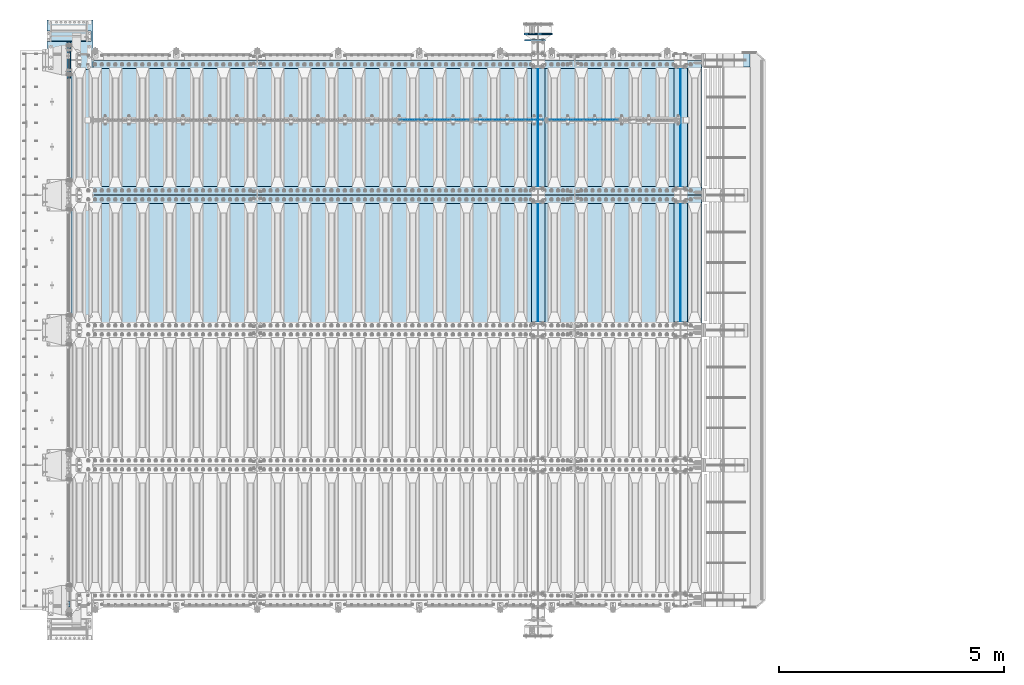
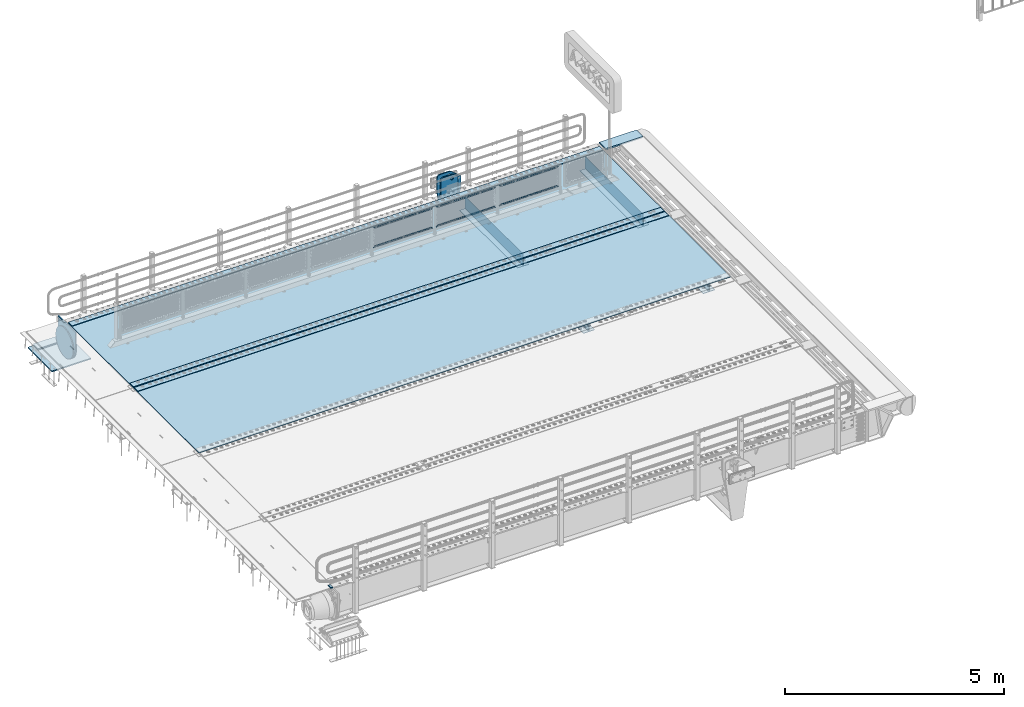
# One storey, part 189 of 240: 27 plates.
"""IFC2X3 building model written with IfcOpenShell, lengths in millimetres."""

from ifc_helpers import new_model, si_unit, frame, origin_with_axes, place, context, subcontext, project, spatial, faceted_brep, material, type_object, element, save


model = new_model("IFC2X3")

# Units and contexts
model_context = context("Model", 3, precision=1e-05, world=origin_with_axes())
body_context = subcontext(model_context, "Body", "Model", "MODEL_VIEW")
ifc_project = project(units=[si_unit("LENGTHUNIT", "METRE", prefix="MILLI"), si_unit("AREAUNIT", "SQUARE_METRE"), si_unit("VOLUMEUNIT", "CUBIC_METRE"), si_unit("MASSUNIT", "GRAM", prefix="KILO"), si_unit("TIMEUNIT", "SECOND"), si_unit("PLANEANGLEUNIT", "RADIAN"), si_unit("SOLIDANGLEUNIT", "STERADIAN"), si_unit("THERMODYNAMICTEMPERATUREUNIT", "DEGREE_CELSIUS"), si_unit("LUMINOUSINTENSITYUNIT", "LUMEN")], contexts=[model_context])

# Site, building, storey
site_placement = place(None, origin_with_axes())
site = spatial("IfcSite", under=ifc_project, at=site_placement, CompositionType="ELEMENT")
building_placement = place(site_placement, origin_with_axes())
building = spatial("IfcBuilding", under=site, at=building_placement, Name="Standard", CompositionType="ELEMENT")
storey_placement = place(building_placement, origin_with_axes())
storey = spatial("IfcBuildingStorey", under=building, at=storey_placement, Name="Undefined", CompositionType="ELEMENT", Elevation=0.0)

# Plates
ifc_material_1 = material()
plate_type_1 = type_object("IfcPlateType", PredefinedType="NOTDEFINED")
plate_1_placement = place(storey_placement, frame((42439.9999999402, 23910.0000004321, -15.9997988354379), z_axis=(-1.0, 0.0, 0.0), x_axis=(0.0, -4.95099997756316e-06, 0.999999999987744)))
element("IfcPlate", 1, at=plate_1_placement, inside=storey, type_object=plate_type_1, material=ifc_material_1, context=body_context, shape_type="Brep", body=[
    faceted_brep([(3.5527136788005e-15, -60.0, 0.0), (-0.000933120085687023, -60.0000000000036, 60.0), (-0.000933120085687023, 60.0, 59.9999999999927), (0.0, 60.0000000000036, -7.27595761418343e-12), (24.9991450303709, -60.0, 60.0), (24.9991450303709, 59.9999999999964, 59.9999999999927), (26.544215218168, -60.0000000000036, 59.7552873850873), (26.544215218168, 60.0, 59.75528738508), (27.9380461396139, -60.0, 59.0451032459096), (27.9380461396139, 60.0, 59.0451032459096), (29.0442025908961, -60.0, 57.9389639895744), (29.0442025908961, 60.0, 57.9389639895744), (29.7544083969366, -60.0, 56.5451441080368), (29.7544083969366, 60.0000000000036, 56.5451441080295), (29.9991450297669, -60.0000000000036, 55.0000777244568), (29.9991450297669, 60.0, 55.0000777244495), (29.999922274335, -60.0, 5.00007772445679), (29.999922274335, 60.0, 5.00007772444951), (29.7552240705896, -60.0000000000036, 3.45497416452417), (29.7552240705896, 60.0, 3.45497416452417), (29.0450346578116, -60.0, 2.06111146690819), (29.0450346578116, 60.0, 2.06111146690819), (27.9388736885073, -60.0, 0.954933302316931), (27.9388736885072, 59.9999999999964, 0.954933302316931), (26.5450220308766, -60.0000000000036, 0.244722222181736), (26.5450220308766, 60.0, 0.244722222181736), (24.9999222749392, -59.9999999999964, 0.0), (24.9999222749392, 60.0, -7.27595761418343e-12)], [[[0, 1, 2, 3]], [[1, 4, 5, 2]], [[4, 6, 7, 5]], [[6, 8, 9, 7]], [[8, 10, 11, 9]], [[10, 12, 13, 11]], [[12, 14, 15, 13]], [[14, 16, 17, 15]], [[16, 18, 19, 17]], [[18, 20, 21, 19]], [[20, 22, 23, 21]], [[22, 24, 25, 23]], [[24, 26, 27, 25]], [[26, 0, 3, 27]], [[5, 7, 9, 11, 13, 15, 17, 19, 21, 23, 25, 27, 3, 2]], [[26, 24, 22, 20, 18, 16, 14, 12, 10, 8, 6, 4, 1, 0]]]),
])
ifc_material_2 = material(Name="STEEL/S355N")
plate_type_2 = type_object("IfcPlateType", PredefinedType="NOTDEFINED")
for number, where, z_axis, x_axis in (
    (2, (56005.0, 32825.0, 0.0), (0.0, 0.0, -1.0), (0.0, -1.0, 0.0)),
    (3, (56005.0, 35825.0, 0.0), (0.0, 0.0, -1.0), (0.0, -1.0, 0.0)),
    (4, (52840.0, 32825.0, 0.0), (0.0, 0.0, -1.0), (0.0, -1.0, 0.0)),
    (5, (52840.0, 35825.0, 0.0), (0.0, 0.0, -1.0), (0.0, -1.0, 0.0)),
):
    element("IfcPlate", number, at=place(storey_placement, frame(where, z_axis=z_axis, x_axis=x_axis)), inside=storey, type_object=plate_type_2, material=ifc_material_2, context=body_context, shape_type="Brep", body=[
        faceted_brep([(0.0, -5.0, 0.0), (0.0, -5.0, 336.0), (0.0, 5.0, 336.0), (0.0, 5.0, 0.0), (2650.0, -5.0, 336.0), (2650.0, 5.0, 336.0), (2650.0, -5.0, 0.0), (2650.0, 5.0, 0.0)], [[[0, 1, 2, 3]], [[1, 4, 5, 2]], [[4, 6, 7, 5]], [[6, 0, 3, 7]], [[5, 7, 3, 2]], [[6, 4, 1, 0]]]),
    ])
plate_type_3 = type_object("IfcPlateType", PredefinedType="NOTDEFINED")
for number, where, z_axis, x_axis in (
    (6, (55855.0, 30175.0, -343.0), (0.0, 1.0, 0.0), (1.0, 0.0, 0.0)),
    (7, (55855.0, 33175.0, -343.0), (0.0, 1.0, 0.0), (1.0, 0.0, 0.0)),
    (8, (52690.0, 30175.0, -343.0), (0.0, 1.0, 0.0), (1.0, 0.0, 0.0)),
    (9, (52690.0, 33175.0, -343.0), (0.0, 1.0, 0.0), (1.0, 0.0, 0.0)),
):
    element("IfcPlate", number, at=place(storey_placement, frame(where, z_axis=z_axis, x_axis=x_axis)), inside=storey, type_object=plate_type_3, material=ifc_material_2, context=body_context, shape_type="Brep", body=[
        faceted_brep([(0.0, -7.0, 0.0), (0.0, -7.0, 2650.0), (0.0, 7.0, 2650.0), (0.0, 7.0, 0.0), (300.0, -7.0, 2650.0), (300.0, 7.0, 2650.0), (300.0, -7.0, 0.0), (300.0, 7.0, 0.0)], [[[0, 1, 2, 3]], [[1, 4, 5, 2]], [[4, 6, 7, 5]], [[6, 0, 3, 7]], [[5, 7, 3, 2]], [[6, 4, 1, 0]]]),
    ])
ifc_material_3 = material(Name="Misc_Undefined")
plate_type_4 = type_object("IfcPlateType", PredefinedType="NOTDEFINED")
plate_2_placement = place(storey_placement, frame((53072.5050117304, 34670.5, 351.520303374641), z_axis=(0.0, 0.0, 1.0), x_axis=(1.0, 0.0, 0.0)))
element("IfcPlate", 10, at=plate_2_placement, inside=storey, type_object=plate_type_4, material=ifc_material_3, context=body_context, shape_type="Brep", body=[
    faceted_brep([(-7.27595761418343e-12, -1.49999999999272, 0.0), (35.000297546394, -1.5, 34.9996948242186), (35.000297546394, 1.5, 34.9996948242186), (0.0, 1.50000000000728, 0.0), (1515.99035644533, -1.5, 34.9999923706054), (1515.99035644533, 1.5, 34.9999923706054), (1550.98999023439, -1.5, 4.43031922259252e-09), (1550.98999023439, 1.5, 4.43031922259252e-09)], [[[0, 1, 2, 3]], [[1, 4, 5, 2]], [[4, 6, 7, 5]], [[6, 0, 3, 7]], [[5, 7, 3, 2]], [[6, 4, 1, 0]]]),
])
plate_3_placement = place(storey_placement, frame((54623.5000001876, 34670.5, 914.520000175701), z_axis=(-0.707103624179501, 0.0, 0.707109938179499), x_axis=(-0.707109938179504, 0.0, -0.707103624179496)))
element("IfcPlate", 11, at=plate_3_placement, inside=storey, type_object=plate_type_4, material=ifc_material_3, context=body_context, shape_type="Brep", body=[
    faceted_brep([(-7.27595761418343e-12, -1.49999999999272, 0.0), (1096.72753906249, -1.5, 1096.7177734375), (1096.72753906249, 1.5, 1096.7177734375), (0.0, 1.50000000000728, 0.0), (1096.72045898437, -1.5, 1047.21337890625), (1096.72045898437, 1.5, 1047.21337890625), (49.4976959228443, -1.5, -1.09139364212751e-10), (49.4976959228443, 1.5, -1.09139364212751e-10)], [[[0, 1, 2, 3]], [[1, 4, 5, 2]], [[4, 6, 7, 5]], [[6, 0, 3, 7]], [[5, 7, 3, 2]], [[6, 4, 1, 0]]]),
])
plate_4_placement = place(storey_placement, frame((51414.5050117304, 34670.5, 351.520303374641), z_axis=(0.0, 0.0, 1.0), x_axis=(1.0, 0.0, 0.0)))
element("IfcPlate", 12, at=plate_4_placement, inside=storey, type_object=plate_type_4, material=ifc_material_3, context=body_context, shape_type="Brep", body=[
    faceted_brep([(-7.27595761418343e-12, -1.49999999999272, 0.0), (35.000297546394, -1.5, 34.9996948242186), (35.000297546394, 1.5, 34.9996948242186), (0.0, 1.50000000000728, 0.0), (1515.99035644533, -1.5, 34.9999923706054), (1515.99035644533, 1.5, 34.9999923706054), (1550.98999023439, -1.5, 4.43031922259252e-09), (1550.98999023439, 1.5, 4.43031922259252e-09)], [[[0, 1, 2, 3]], [[1, 4, 5, 2]], [[4, 6, 7, 5]], [[6, 0, 3, 7]], [[5, 7, 3, 2]], [[6, 4, 1, 0]]]),
])
plate_5_placement = place(storey_placement, frame((52965.5000001876, 34670.5, 914.520000175701), z_axis=(-0.707103624179501, 0.0, 0.707109938179499), x_axis=(-0.707109938179504, 0.0, -0.707103624179496)))
element("IfcPlate", 13, at=plate_5_placement, inside=storey, type_object=plate_type_4, material=ifc_material_3, context=body_context, shape_type="Brep", body=[
    faceted_brep([(-7.27595761418343e-12, -1.49999999999272, 0.0), (1096.72753906249, -1.5, 1096.7177734375), (1096.72753906249, 1.5, 1096.7177734375), (0.0, 1.50000000000728, 0.0), (1096.72045898437, -1.5, 1047.21337890625), (1096.72045898437, 1.5, 1047.21337890625), (49.4976959228443, -1.5, -1.09139364212751e-10), (49.4976959228443, 1.5, -1.09139364212751e-10)], [[[0, 1, 2, 3]], [[1, 4, 5, 2]], [[4, 6, 7, 5]], [[6, 0, 3, 7]], [[5, 7, 3, 2]], [[6, 4, 1, 0]]]),
])
plate_6_placement = place(storey_placement, frame((49756.5050117304, 34670.5, 351.520303374641), z_axis=(0.0, 0.0, 1.0), x_axis=(1.0, 0.0, 0.0)))
element("IfcPlate", 14, at=plate_6_placement, inside=storey, type_object=plate_type_4, material=ifc_material_3, context=body_context, shape_type="Brep", body=[
    faceted_brep([(-7.27595761418343e-12, -1.49999999999272, 0.0), (35.000297546394, -1.5, 34.9996948242186), (35.000297546394, 1.5, 34.9996948242186), (0.0, 1.50000000000728, 0.0), (1515.99035644533, -1.5, 34.9999923706054), (1515.99035644533, 1.5, 34.9999923706054), (1550.98999023439, -1.5, 4.43031922259252e-09), (1550.98999023439, 1.5, 4.43031922259252e-09)], [[[0, 1, 2, 3]], [[1, 4, 5, 2]], [[4, 6, 7, 5]], [[6, 0, 3, 7]], [[5, 7, 3, 2]], [[6, 4, 1, 0]]]),
])
plate_7_placement = place(storey_placement, frame((51307.5000001876, 34670.5, 914.520000175701), z_axis=(-0.707103624179501, 0.0, 0.707109938179499), x_axis=(-0.707109938179504, 0.0, -0.707103624179496)))
element("IfcPlate", 15, at=plate_7_placement, inside=storey, type_object=plate_type_4, material=ifc_material_3, context=body_context, shape_type="Brep", body=[
    faceted_brep([(-7.27595761418343e-12, -1.49999999999272, 0.0), (1096.72753906249, -1.5, 1096.7177734375), (1096.72753906249, 1.5, 1096.7177734375), (0.0, 1.50000000000728, 0.0), (1096.72045898437, -1.5, 1047.21337890625), (1096.72045898437, 1.5, 1047.21337890625), (49.4976959228443, -1.5, -1.09139364212751e-10), (49.4976959228443, 1.5, -1.09139364212751e-10)], [[[0, 1, 2, 3]], [[1, 4, 5, 2]], [[4, 6, 7, 5]], [[6, 0, 3, 7]], [[5, 7, 3, 2]], [[6, 4, 1, 0]]]),
])
plate_type_5 = type_object("IfcPlateType", PredefinedType="NOTDEFINED")
plate_8_placement = place(storey_placement, frame((56556.9988298905, 36150.0, -10.0000000004865), z_axis=(1.0, 0.0, 0.0), x_axis=(0.0, -1.0, 0.0)))
element("IfcPlate", 16, at=plate_8_placement, inside=storey, type_object=plate_type_5, material=ifc_material_2, context=body_context, shape_type="Brep", body=[
    faceted_brep([(300.0, 7.0, 986.0), (300.0, 20.0, 956.0), (-3.63797880709171e-11, 20.0, 956.0), (-3.63797880709171e-11, 7.0, 986.0), (0.0, 20.0, 0.0), (0.0, -20.0, 0.0), (-3.63797880709171e-11, -20.0, 986.0), (300.0, -20.0, 986.0), (300.0, -20.0, -1.81898940354586e-12), (300.0, 20.0, -1.81898940354586e-12)], [[[0, 1, 2, 3]], [[4, 5, 6, 3, 2]], [[6, 7, 0, 3]], [[7, 8, 9, 1, 0]], [[8, 5, 4, 9]], [[9, 4, 2, 1]], [[8, 7, 6, 5]]]),
])
plate_type_6 = type_object("IfcPlateType", PredefinedType="NOTDEFINED")
plate_9_placement = place(storey_placement, frame((42905.0, 36645.0, -803.000000000004), z_axis=(0.0, -1.0, 0.0), x_axis=(-1.0, 0.0, 0.0)))
element("IfcPlate", 17, at=plate_9_placement, inside=storey, type_object=plate_type_6, material=ifc_material_1, context=body_context, shape_type="Brep", body=[
    faceted_brep([(0.0, 0.0, 235.0), (0.0, -15.0, 220.0), (979.0, -15.0, 220.0), (979.0, 0.0, 235.0), (0.0, 15.0, 235.0), (0.0, 15.0, 0.0), (0.0, -15.0, 0.0), (979.0, 15.0, 235.0), (979.0, -15.0, 0.0), (979.0, 15.0, 0.0)], [[[0, 1, 2, 3]], [[4, 5, 6, 1, 0]], [[7, 4, 0, 3]], [[8, 9, 7, 3, 2]], [[8, 6, 5, 9]], [[7, 9, 5, 4]], [[6, 8, 2, 1]]]),
])
plate_type_7 = type_object("IfcPlateType", PredefinedType="NOTDEFINED")
plate_10_placement = place(storey_placement, frame((41926.0, 36890.0, -1043.0), z_axis=(1.0, 0.0, 0.0), x_axis=(0.0, -1.0, 0.0)))
element("IfcPlate", 18, at=plate_10_placement, inside=storey, type_object=plate_type_7, material=ifc_material_1, context=body_context, shape_type="Brep", body=[
    faceted_brep([(0.0, -15.0, 0.0), (3.03448323393241e-05, -15.0, 1025.0), (3.03448323393241e-05, 15.0, 1025.0), (0.0, 15.0, 0.0), (1100.0, -15.0, 1025.0), (1100.0, 15.0, 1025.0), (1100.0, -15.0, -2.18278728425503e-11), (1100.0, 15.0, -2.18278728425503e-11)], [[[0, 1, 2, 3]], [[1, 4, 5, 2]], [[4, 6, 7, 5]], [[6, 0, 3, 7]], [[5, 7, 3, 2]], [[6, 4, 1, 0]]]),
])
plate_type_8 = type_object("IfcPlateType", PredefinedType="NOTDEFINED")
plate_11_placement = place(storey_placement, frame((42387.5, 36400.0, -114.999999999998), z_axis=(0.0, 0.0, -1.0), x_axis=(0.0, -1.0, 0.0)))
element("IfcPlate", 19, at=plate_11_placement, inside=storey, type_object=plate_type_8, material=ifc_material_2, context=body_context, shape_type="Brep", body=[
    faceted_brep([(0.0, -12.5, 400.0), (2.91645036072441, -12.5, 448.214672101647), (2.91645036072441, 12.5, 448.214672101647), (0.0, 12.5, 400.0), (11.6232730294796, -12.5, 495.726265714562), (11.6232730294796, 12.5, 495.726265714562), (25.9935029256958, -12.5, 541.841954816598), (25.9935029256958, 12.5, 541.841954816598), (45.8175897385445, -12.5, 585.889268817169), (45.8175897385445, 12.5, 585.889268817169), (70.8064536423408, -12.5, 627.22589869221), (70.8064536423408, 12.5, 627.22589869221), (100.595700731341, -12.5, 665.24906329616), (100.595700731341, 12.5, 665.24906329616), (134.750936703451, -12.5, 699.40429926839), (134.750936703451, 12.5, 699.40429926839), (172.774101307281, -12.5, 729.193546357525), (172.774101307281, 12.5, 729.193546357525), (214.11073118222, -12.5, 754.182410261448), (214.11073118222, 12.5, 754.182410261448), (258.158045182681, -12.5, 774.006497074428), (258.158045182681, 12.5, 774.006497074428), (304.273734284623, -12.5, 788.376726970779), (304.273734284623, 12.5, 788.376726970779), (351.785327897465, -12.5, 797.083549639658), (351.785327897465, 12.5, 797.083549639658), (400.0, -12.5, 800.0), (400.0, 12.5, 800.0), (448.21467210335, -12.5, 797.083549637646), (448.21467210335, 12.5, 797.083549637646), (495.726265715995, -12.5, 788.37672696916), (495.726265715995, 12.5, 788.37672696916), (541.841954817748, -12.5, 774.006497073235), (541.841954817748, 12.5, 774.006497073235), (585.889268818006, -12.5, 754.182410260695), (585.889268818006, 12.5, 754.182410260695), (627.225898692734, -12.5, 729.193546357212), (627.225898692734, 12.5, 729.193546357212), (665.24906329636, -12.5, 699.404299268539), (665.24906329636, 12.5, 699.404299268539), (699.404299268259, -12.5, 665.24906329676), (699.404299268259, 12.5, 665.24906329676), (729.193546357063, -12.5, 627.22589869325), (729.193546357063, 12.5, 627.22589869325), (754.18241026067, -12.5, 585.889268818639), (754.18241026067, 12.5, 585.889268818639), (774.006497073351, -12.5, 541.841954818479), (774.006497073351, 12.5, 541.841954818479), (788.376726969393, -12.5, 495.726265716821), (788.376726969393, 12.5, 495.726265716821), (797.083549638002, -12.5, 448.214672104252), (797.083549638002, 12.5, 448.214672104252), (800.0, -12.5, 400.0), (800.0, 12.5, 400.0), (797.083549639283, -12.5, 351.785327898364), (797.083549639283, 12.5, 351.785327898364), (788.376726970528, -12.5, 304.273734285453), (788.376726970528, 12.5, 304.273734285453), (774.006497074311, -12.5, 258.158045183416), (774.006497074311, 12.5, 258.158045183416), (754.182410261463, -12.5, 214.110731182853), (754.182410261463, 12.5, 214.110731182853), (729.193546357659, -12.5, 172.774101307812), (729.193546357659, 12.5, 172.774101307812), (699.404299268659, -12.5, 134.750936703855), (699.404299268659, 12.5, 134.750936703855), (665.249063296564, -12.5, 100.595700731628), (665.249063296564, 12.5, 100.595700731628), (627.225898692719, -12.5, 70.8064536425045), (627.225898692719, 12.5, 70.8064536425045), (585.889268817788, -12.5, 45.8175897385809), (585.889268817788, 12.5, 45.8175897385809), (541.841954817326, -12.5, 25.9935029256012), (541.841954817326, 12.5, 25.9935029256012), (495.726265715377, -12.5, 11.6232730292504), (495.726265715377, 12.5, 11.6232730292504), (448.214672102542, -12.5, 2.91645036037517), (448.214672102542, 12.5, 2.91645036037517), (400.0, -12.5, -5.6843418860808e-14), (400.0, 12.5, -5.6843418860808e-14), (351.785327896665, -12.5, 2.91645036236514), (351.785327896665, 12.5, 2.91645036236514), (304.273734284012, -12.5, 11.6232730308511), (304.273734284012, 12.5, 11.6232730308511), (258.158045182267, -12.5, 25.9935029267763), (258.158045182267, 12.5, 25.9935029267763), (214.110731182009, -12.5, 45.8175897393157), (214.110731182009, 12.5, 45.8175897393157), (172.774101307281, -12.5, 70.8064536427992), (172.774101307281, 12.5, 70.8064536427992), (134.750936703655, -12.5, 100.595700731472), (134.750936703655, 12.5, 100.595700731472), (100.595700731748, -12.5, 134.750936703247), (100.595700731748, 12.5, 134.750936703247), (70.8064536429447, -12.5, 172.774101306761), (70.8064536429447, 12.5, 172.774101306761), (45.8175897393376, -12.5, 214.110731181379), (45.8175897393376, 12.5, 214.110731181379), (25.9935029266635, -12.5, 258.158045181532), (25.9935029266635, 12.5, 258.158045181532), (11.6232730306074, -12.5, 304.273734283186), (11.6232730306074, 12.5, 304.273734283186), (2.9164503619977, -12.5, 351.785327895759), (2.9164503619977, 12.5, 351.785327895759)], [[[0, 1, 2, 3]], [[1, 4, 5, 2]], [[4, 6, 7, 5]], [[6, 8, 9, 7]], [[8, 10, 11, 9]], [[10, 12, 13, 11]], [[12, 14, 15, 13]], [[14, 16, 17, 15]], [[16, 18, 19, 17]], [[18, 20, 21, 19]], [[20, 22, 23, 21]], [[22, 24, 25, 23]], [[24, 26, 27, 25]], [[26, 28, 29, 27]], [[28, 30, 31, 29]], [[30, 32, 33, 31]], [[32, 34, 35, 33]], [[34, 36, 37, 35]], [[36, 38, 39, 37]], [[38, 40, 41, 39]], [[40, 42, 43, 41]], [[42, 44, 45, 43]], [[44, 46, 47, 45]], [[46, 48, 49, 47]], [[48, 50, 51, 49]], [[50, 52, 53, 51]], [[52, 54, 55, 53]], [[54, 56, 57, 55]], [[56, 58, 59, 57]], [[58, 60, 61, 59]], [[60, 62, 63, 61]], [[62, 64, 65, 63]], [[64, 66, 67, 65]], [[66, 68, 69, 67]], [[68, 70, 71, 69]], [[70, 72, 73, 71]], [[72, 74, 75, 73]], [[74, 76, 77, 75]], [[76, 78, 79, 77]], [[78, 80, 81, 79]], [[80, 82, 83, 81]], [[82, 84, 85, 83]], [[84, 86, 87, 85]], [[86, 88, 89, 87]], [[88, 90, 91, 89]], [[90, 92, 93, 91]], [[92, 94, 95, 93]], [[94, 96, 97, 95]], [[96, 98, 99, 97]], [[98, 100, 101, 99]], [[100, 102, 103, 101]], [[102, 0, 3, 103]], [[5, 7, 9, 11, 13, 15, 17, 19, 21, 23, 25, 27, 29, 31, 33, 35, 37, 39, 41, 43, 45, 47, 49, 51, 53, 55, 57, 59, 61, 63, 65, 67, 69, 71, 73, 75, 77, 79, 81, 83, 85, 87, 89, 91, 93, 95, 97, 99, 101, 103, 3, 2]], [[102, 100, 98, 96, 94, 92, 90, 88, 86, 84, 82, 80, 78, 76, 74, 72, 70, 68, 66, 64, 62, 60, 58, 56, 54, 52, 50, 48, 46, 44, 42, 40, 38, 36, 34, 32, 30, 28, 26, 24, 22, 20, 18, 16, 14, 12, 10, 8, 6, 4, 1, 0]]]),
])
ifc_material_4 = material(Name="STEEL/S235JR")
plate_type_9 = type_object("IfcPlateType", PredefinedType="NOTDEFINED")
for number, where, z_axis, x_axis in (
    (20, (56467.0, 32815.0, 20.0), (-1.0, 0.0, 0.0), (0.0, 1.0, 0.0)),
    (21, (56467.0, 35815.0, 20.0), (-1.0, 0.0, 0.0), (0.0, 1.0, 0.0)),
    (22, (56467.0, 33015.0, 20.0), (-1.0, 0.0, 0.0), (0.0, 1.0, 0.0)),
):
    element("IfcPlate", number, at=place(storey_placement, frame(where, z_axis=z_axis, x_axis=x_axis)), inside=storey, type_object=plate_type_9, material=ifc_material_4, context=body_context, shape_type="Brep", body=[
        faceted_brep([(0.0, -6.0, 0.0), (0.0, -6.0, 13997.0), (0.0, 6.0, 13997.0), (0.0, 6.0, 0.0), (170.0, -6.0, 13997.0), (170.0, 6.0, 13997.0), (170.0, -6.0, 0.0), (170.0, 6.0, 0.0)], [[[0, 1, 2, 3]], [[1, 4, 5, 2]], [[4, 6, 7, 5]], [[6, 0, 3, 7]], [[5, 7, 3, 2]], [[6, 4, 1, 0]]]),
    ])
plate_type_10 = type_object("IfcPlateType", PredefinedType="NOTDEFINED")
for number, where, z_axis, x_axis in (
    (23, (42460.0, 32995.0, 7.0), (1.0, 0.0, 0.0), (0.0, -1.0, 0.0)),
    (24, (42460.0, 35995.0, 7.0), (1.0, 0.0, 0.0), (0.0, -1.0, 0.0)),
):
    element("IfcPlate", number, at=place(storey_placement, frame(where, z_axis=z_axis, x_axis=x_axis)), inside=storey, type_object=plate_type_10, material=ifc_material_2, context=body_context, shape_type="Brep", body=[
        faceted_brep([(0.0, -7.0, 0.0), (-2.96859070658684e-09, -7.0, 14017.0), (-2.96859070658684e-09, 7.0, 14017.0), (0.0, 7.0, 0.0), (2990.0, -7.0, 14017.0), (2990.0, 7.0, 14017.0), (2990.0, -7.0, 0.0), (2990.0, 7.0, 0.0)], [[[0, 1, 2, 3]], [[1, 4, 5, 2]], [[4, 6, 7, 5]], [[6, 0, 3, 7]], [[5, 7, 3, 2]], [[6, 4, 1, 0]]]),
    ])
plate_type_11 = type_object("IfcPlateType", PredefinedType="NOTDEFINED")
plate_12_placement = place(storey_placement, frame((42445.0, 35600.0, -20.0), z_axis=(0.0, 1.0, 0.0), x_axis=(0.0, 0.0, -1.0)))
element("IfcPlate", 25, at=plate_12_placement, inside=storey, type_object=plate_type_11, material=ifc_material_2, context=body_context, shape_type="Brep", body=[
    faceted_brep([(855.0, -15.0, 572.96311467154), (855.0, 15.0, 572.96311467154), (849.182410261294, 15.0, 585.889268817533), (849.182410261294, -15.0, 585.889268817533), (824.193546357474, 15.0, 627.225898692486), (824.193546357474, -15.0, 627.225898692486), (794.404299268454, 15.0, 665.249063296338), (794.404299268454, -15.0, 665.249063296338), (760.249063296334, 15.0, 699.404299268463), (760.249063296334, -15.0, 699.404299268463), (722.22589869248, 15.0, 729.193546357485), (722.22589869248, -15.0, 729.193546357485), (680.889268817528, 15.0, 754.18241026131), (680.889268817528, -15.0, 754.18241026131), (636.841954817037, 15.0, 774.006497074195), (636.841954817037, -15.0, 774.006497074195), (590.726265715048, 15.0, 788.376726970448), (590.726265715048, -15.0, 788.376726970448), (543.214672102156, 15.0, 797.083549639254), (543.214672102156, -15.0, 797.083549639254), (495.0, -15.0, 800.000000000029), (495.0, 15.0, 800.0), (494.999999999412, -15.0, 0.0), (494.999999999412, 15.0, 0.0), (543.214672102129, 15.0, 2.91645036080809), (543.214672102129, -15.0, 2.91645036080809), (590.726265715023, 15.0, 11.6232730296069), (590.726265715023, -15.0, 11.6232730296069), (636.841954817014, 15.0, 25.9935029258631), (636.841954817014, -15.0, 25.9935029258631), (680.889268817507, 15.0, 45.8175897387446), (680.889268817507, -15.0, 45.8175897387446), (722.225898692462, 15.0, 70.8064536425663), (722.225898692462, -15.0, 70.8064536425663), (760.249063296318, 15.0, 100.595700731588), (760.249063296318, -15.0, 100.595700731588), (794.404299268441, 15.0, 134.750936703713), (794.404299268441, -15.0, 134.750936703713), (824.193546357463, 15.0, 172.774101307565), (824.193546357463, -15.0, 172.774101307565), (849.182410261284, 15.0, 214.110731182518), (849.182410261284, -15.0, 214.110731182518), (855.0, -15.0, 227.036885328533), (855.0, 15.0, 227.036885328533), (0.0, -15.0, 0.0), (0.0, 15.0, 0.0), (0.0, 15.0, 800.0), (0.0, -15.0, 800.0)], [[[0, 1, 2, 3]], [[3, 2, 4, 5]], [[5, 4, 6, 7]], [[7, 6, 8, 9]], [[9, 8, 10, 11]], [[11, 10, 12, 13]], [[13, 12, 14, 15]], [[15, 14, 16, 17]], [[17, 16, 18, 19]], [[20, 19, 18, 21]], [[22, 23, 24, 25]], [[25, 24, 26, 27]], [[27, 26, 28, 29]], [[29, 28, 30, 31]], [[31, 30, 32, 33]], [[33, 32, 34, 35]], [[35, 34, 36, 37]], [[37, 36, 38, 39]], [[39, 38, 40, 41]], [[42, 41, 40, 43]], [[42, 43, 1, 0]], [[44, 45, 23, 22]], [[16, 14, 12, 10, 8, 6, 4, 2, 1, 43, 40, 38, 36, 34, 32, 30, 28, 26, 24, 23, 45, 46, 21, 18]], [[44, 47, 46, 45]], [[46, 47, 20, 21]], [[47, 44, 22, 25, 27, 29, 31, 33, 35, 37, 39, 41, 42, 0, 3, 5, 7, 9, 11, 13, 15, 17, 19, 20]]]),
])
plate_type_12 = type_object("IfcPlateType", PredefinedType="NOTDEFINED")
plate_13_placement = place(storey_placement, frame((52999.9999999964, 36440.0000000348, -945.000018222272), z_axis=(-0.901283188008789, 0.0, 0.433230441004224), x_axis=(-0.433230441004219, 0.0, -0.901283188008791)))
element("IfcPlate", 26, at=plate_13_placement, inside=storey, type_object=plate_type_12, material=ifc_material_2, context=body_context, shape_type="Brep", body=[
    faceted_brep([(-929.368911797577, -15.0000000000146, 583.252555032144), (-929.368911797577, 14.9999999999854, 583.252555032144), (-937.308302015026, 14.9999999999854, 596.689503306923), (-937.308302015026, -15.0000000000146, 596.689503306923), (-939.501244651245, 14.9999999999854, 612.141897896698), (-939.501244651245, -15.0000000000146, 612.141897896698), (-935.613884068938, 14.9999999999854, 627.257251801486), (-935.613884068938, -15.0000000000146, 627.257251801486), (-926.238035677761, 14.9999999999854, 639.734389410303), (-926.238035677761, -15.0000000000146, 639.734389410303), (-912.801087402986, 14.9999999999854, 647.673779627759), (-912.801087402986, -15.0000000000146, 647.673779627759), (-897.348692813208, 14.9999999999854, 649.866722263971), (-897.348692813208, -15.0000000000146, 649.866722263971), (-882.23333890842, 14.9999999999854, 645.979361681668), (-882.23333890842, -15.0000000000146, 645.979361681668), (-869.756201299595, 14.9999999999854, 636.603513290487), (-869.756201299595, -15.0000000000146, 636.603513290487), (-861.81681108215, 14.9999999999854, 623.166565015716), (-861.81681108215, -15.0000000000146, 623.166565015716), (-859.623868445931, 14.9999999999854, 607.714170425934), (-859.623868445931, -15.0000000000146, 607.714170425934), (-863.511229028238, 14.9999999999854, 592.598816521153), (-863.511229028238, -15.0000000000146, 592.598816521153), (-872.887077419415, 14.9999999999854, 580.121678912328), (-872.887077419415, -15.0000000000146, 580.121678912328), (-886.32402569419, 14.9999999999854, 572.182288694879), (-886.32402569419, -15.0000000000146, 572.182288694879), (-901.776420283964, 14.9999999999854, 569.989346058661), (-901.776420283964, -15.0000000000146, 569.989346058661), (-916.891774188756, 14.9999999999854, 573.876706640964), (-916.891774188756, -15.0000000000146, 573.876706640964), (264.34993529279, -15.0, 42.1349931512304), (264.34993529279, 15.0, 42.1349931512304), (15.5957837248316, 15.0, 161.706590867936), (15.5957837248316, -15.0000000000073, 161.706590867936), (244.096420288082, -15.0, 2.25554686039686e-10), (244.096420288082, 15.0, 2.25554686039686e-10), (0.0, -15.0, 0.0), (0.0, 15.0, 0.0), (-976.801696777344, -15.0, 469.530822753899), (-976.801696777344, 15.0, 469.530822753899), (-1005.61094458149, -15.0, 584.572384687111), (-1005.61094458149, 15.0, 584.572384687111), (-1008.62082262311, -15.0, 603.3791105032), (-1008.62082262311, 15.0, 603.3791105032), (-1008.34150017789, -15.0, 622.423119553736), (-1008.34150017789, 15.0, 622.423119553736), (-1004.7813512013, -15.0, 641.133481415818), (-1004.7813512013, 15.0, 641.133481415818), (-998.047107283008, -15.0, 658.949268252029), (-998.047107283008, 15.0, 658.949268252029), (-903.393044122804, -15.0, 855.865689234553), (-903.393044122804, 15.0, 855.865689234553), (-891.965944990749, -15.0, 873.346279725993), (-891.965944990749, 15.0, 873.346279725993), (-876.403904176859, -15.0, 887.273681644823), (-876.403904176859, 15.0, 887.273681644823), (-857.767449567884, -15.0, 896.698765098517), (-857.767449567884, 15.0, 896.698765098517), (-837.326625373305, -15.0, 900.97922590877), (-837.326625373305, 15.0, 900.97922590877), (-816.474440668644, -15.0, 899.823357601352), (-816.474440668644, 15.0, 899.823357601352), (-796.631938081966, -15.0, 893.3099307304), (-796.631938081966, 15.0, 893.3099307304), (-427.105834960938, -15.0, 715.685424804673), (-427.105834960938, 15.0, 715.685424804673), (138.633743286129, -15.0, 288.410614013665), (138.633743286129, 15.0, 288.410614013665), (291.101898193352, -15.0, 97.7892227172706), (291.101898193352, 15.0, 97.7892227172706), (270.848389278413, -15.0, 55.6542422352941), (270.848389278413, 15.0, 55.6542422352941), (22.0942403398949, -15.0000000000073, 175.225838688071), (22.0942403398949, 15.0, 175.225838688071), (-855.850321927563, -15.0, 588.916357775808), (-852.143242469345, -15.0, 592.234043547585), (-847.175983338977, -15.0, 591.958700631338), (-843.858297567211, -15.0, 588.251621173127), (-844.133640483451, -15.0, 583.284362042752), (-847.840719941669, -15.0, 579.966676270989), (-852.807979072033, -15.0, 580.242019187222), (-856.125664843803, -15.0, 583.949098645448), (-844.133640483451, 15.0, 583.284362042752), (-847.840719941669, 15.0, 579.966676270989), (-843.858297567211, 15.0, 588.251621173127), (-847.175983338977, 15.0, 591.958700631338), (-852.143242469345, 15.0, 592.234043547585), (-855.850321927563, 15.0, 588.916357775808), (-856.125664843803, 15.0, 583.949098645448), (-852.807979072033, 15.0, 580.242019187222)], [[[0, 1, 2, 3]], [[3, 2, 4, 5]], [[5, 4, 6, 7]], [[7, 6, 8, 9]], [[9, 8, 10, 11]], [[11, 10, 12, 13]], [[13, 12, 14, 15]], [[15, 14, 16, 17]], [[17, 16, 18, 19]], [[19, 18, 20, 21]], [[21, 20, 22, 23]], [[23, 22, 24, 25]], [[25, 24, 26, 27]], [[27, 26, 28, 29]], [[29, 28, 30, 31]], [[31, 30, 1, 0]], [[32, 33, 34, 35]], [[36, 37, 33, 32]], [[36, 38, 39, 37]], [[38, 40, 41, 39]], [[40, 42, 43, 41]], [[42, 44, 45, 43]], [[44, 46, 47, 45]], [[46, 48, 49, 47]], [[48, 50, 51, 49]], [[50, 52, 53, 51]], [[52, 54, 55, 53]], [[54, 56, 57, 55]], [[56, 58, 59, 57]], [[58, 60, 61, 59]], [[60, 62, 63, 61]], [[62, 64, 65, 63]], [[64, 66, 67, 65]], [[66, 68, 69, 67]], [[68, 70, 71, 69]], [[71, 70, 72, 73]], [[74, 75, 73, 72]], [[35, 34, 75, 74]], [[72, 70, 68, 66, 64, 62, 60, 58, 56, 54, 52, 50, 48, 46, 44, 42, 40, 38, 36, 32, 35, 74], [3, 5, 7, 9, 11, 13, 15, 17, 19, 21, 23, 25, 27, 29, 31, 0], [76, 77, 78, 79, 80, 81, 82, 83]], [[80, 84, 85, 81]], [[79, 86, 84, 80]], [[78, 87, 86, 79]], [[77, 88, 87, 78]], [[76, 89, 88, 77]], [[83, 90, 89, 76]], [[82, 91, 90, 83]], [[81, 85, 91, 82]], [[37, 39, 41, 43, 45, 47, 49, 51, 53, 55, 57, 59, 61, 63, 65, 67, 69, 71, 73, 75, 34, 33], [26, 24, 22, 20, 18, 16, 14, 12, 10, 8, 6, 4, 2, 1, 30, 28], [84, 86, 87, 88, 89, 90, 91, 85]]]),
])
plate_type_13 = type_object("IfcPlateType", PredefinedType="NOTDEFINED")
plate_14_placement = place(storey_placement, frame((52990.0, 36580.0000000345, -1470.00001822227), z_axis=(0.0, 0.0, 1.0), x_axis=(-1.0, 0.0, 0.0)))
element("IfcPlate", 27, at=plate_14_placement, inside=storey, type_object=plate_type_13, material=ifc_material_2, context=body_context, shape_type="Brep", body=[
    faceted_brep([(113.044818699549, -15.0, 1615.3073372946), (113.044818699549, 15.0, 1615.3073372946), (121.715728752541, 15.0, 1628.28427124746), (121.715728752541, -15.0, 1628.28427124746), (134.692662705398, 15.0, 1636.95518130045), (134.692662705398, -15.0, 1636.95518130045), (150.0, 15.0, 1640.0), (150.0, -15.0, 1640.0), (165.307337294602, 15.0, 1636.95518130045), (165.307337294602, -15.0, 1636.95518130045), (178.284271247459, 15.0, 1628.28427124746), (178.284271247459, -15.0, 1628.28427124746), (186.955181300451, 15.0, 1615.3073372946), (186.955181300451, -15.0, 1615.3073372946), (190.0, 15.0, 1600.0), (190.0, -15.0, 1600.0), (186.955181300451, 15.0, 1584.6926627054), (186.955181300451, -15.0, 1584.6926627054), (178.284271247459, 15.0, 1571.71572875254), (178.284271247459, -15.0, 1571.71572875254), (165.307337294602, 15.0, 1563.04481869955), (165.307337294602, -15.0, 1563.04481869955), (150.0, 15.0, 1560.0), (150.0, -15.0, 1560.0), (134.692662705398, 15.0, 1563.04481869955), (134.692662705398, -15.0, 1563.04481869955), (121.715728752541, 15.0, 1571.71572875254), (121.715728752541, -15.0, 1571.71572875254), (113.044818699549, 15.0, 1584.6926627054), (113.044818699549, -15.0, 1584.6926627054), (110.0, 15.0, 1600.0), (110.0, -15.0, 1600.0), (300.0, -15.0, 0.0), (0.0, -15.0, 0.0), (0.0, 15.0, 0.0), (300.0, 15.0, 0.0), (462.5, -15.0, 1210.0), (462.5, 15.0, 1210.0), (462.5, -15.0, 1630.0), (462.5, 15.0, 1630.0), (459.774066103128, -15.0, 1650.7055236082), (459.774066103128, 15.0, 1650.7055236082), (451.782032302755, -15.0, 1670.0), (451.782032302755, 15.0, 1670.0), (439.068542494926, -15.0, 1686.56854249492), (439.068542494926, 15.0, 1686.56854249492), (422.5, -15.0, 1699.28203230276), (422.5, 15.0, 1699.28203230276), (403.205523608201, -15.0, 1707.27406610313), (403.205523608201, 15.0, 1707.27406610313), (382.5, -15.0, 1710.0), (382.5, 15.0, 1710.0), (151.788081037077, -15.0, 1710.0), (151.788081037077, 15.0, 1710.0), (132.694887325029, -15.0, 1708.33028179541), (132.694887325029, 15.0, 1708.33028179541), (114.181334578883, -15.0, 1703.37181734316), (114.181334578883, 15.0, 1703.37181734316), (96.8094667268524, -15.0, 1695.27513824985), (96.8094667268524, 15.0, 1695.27513824985), (81.1066678416755, -15.0, 1684.28604765144), (81.1066678416755, 15.0, 1684.28604765144), (-162.5, -15.0, 1480.0), (-162.5, 15.0, 1480.0), (-162.5, -15.0, 1210.0), (-162.5, 15.0, 1210.0), (150.0, -15.0000000000036, 1551.5), (154.596194077712, -15.0000000000036, 1549.59619407771), (156.5, -15.0000000000036, 1545.0), (154.596194077712, -15.0000000000036, 1540.40380592229), (150.0, -15.0000000000036, 1538.5), (145.403805922288, -15.0000000000036, 1540.40380592229), (143.5, -15.0000000000036, 1545.0), (145.403805922288, -15.0000000000036, 1549.59619407771), (150.0, 14.9999999999964, 1538.5), (145.403805922288, 14.9999999999964, 1540.40380592229), (154.596194077712, 14.9999999999964, 1540.40380592229), (156.5, 14.9999999999964, 1545.0), (154.596194077712, 14.9999999999964, 1549.59619407771), (150.0, 14.9999999999964, 1551.5), (145.403805922288, 14.9999999999964, 1549.59619407771), (143.5, 14.9999999999964, 1545.0)], [[[0, 1, 2, 3]], [[3, 2, 4, 5]], [[5, 4, 6, 7]], [[7, 6, 8, 9]], [[9, 8, 10, 11]], [[11, 10, 12, 13]], [[13, 12, 14, 15]], [[15, 14, 16, 17]], [[17, 16, 18, 19]], [[19, 18, 20, 21]], [[21, 20, 22, 23]], [[23, 22, 24, 25]], [[25, 24, 26, 27]], [[27, 26, 28, 29]], [[29, 28, 30, 31]], [[31, 30, 1, 0]], [[32, 33, 34, 35]], [[36, 32, 35, 37]], [[38, 36, 37, 39]], [[40, 38, 39, 41]], [[42, 40, 41, 43]], [[44, 42, 43, 45]], [[46, 44, 45, 47]], [[48, 46, 47, 49]], [[50, 48, 49, 51]], [[52, 50, 51, 53]], [[54, 52, 53, 55]], [[56, 54, 55, 57]], [[58, 56, 57, 59]], [[60, 58, 59, 61]], [[62, 60, 61, 63]], [[64, 62, 63, 65]], [[33, 64, 65, 34]], [[32, 36, 38, 40, 42, 44, 46, 48, 50, 52, 54, 56, 58, 60, 62, 64, 33], [3, 5, 7, 9, 11, 13, 15, 17, 19, 21, 23, 25, 27, 29, 31, 0], [66, 67, 68, 69, 70, 71, 72, 73]], [[70, 74, 75, 71]], [[69, 76, 74, 70]], [[68, 77, 76, 69]], [[67, 78, 77, 68]], [[66, 79, 78, 67]], [[73, 80, 79, 66]], [[72, 81, 80, 73]], [[71, 75, 81, 72]], [[63, 61, 59, 57, 55, 53, 51, 49, 47, 45, 43, 41, 39, 37, 35, 34, 65], [26, 24, 22, 20, 18, 16, 14, 12, 10, 8, 6, 4, 2, 1, 30, 28], [74, 76, 77, 78, 79, 80, 81, 75]]]),
])

save(model, "model.ifc")
